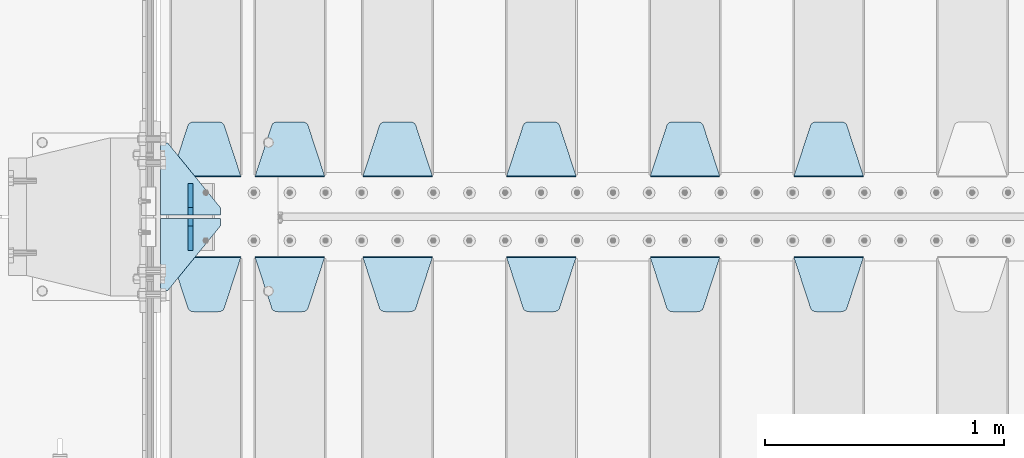
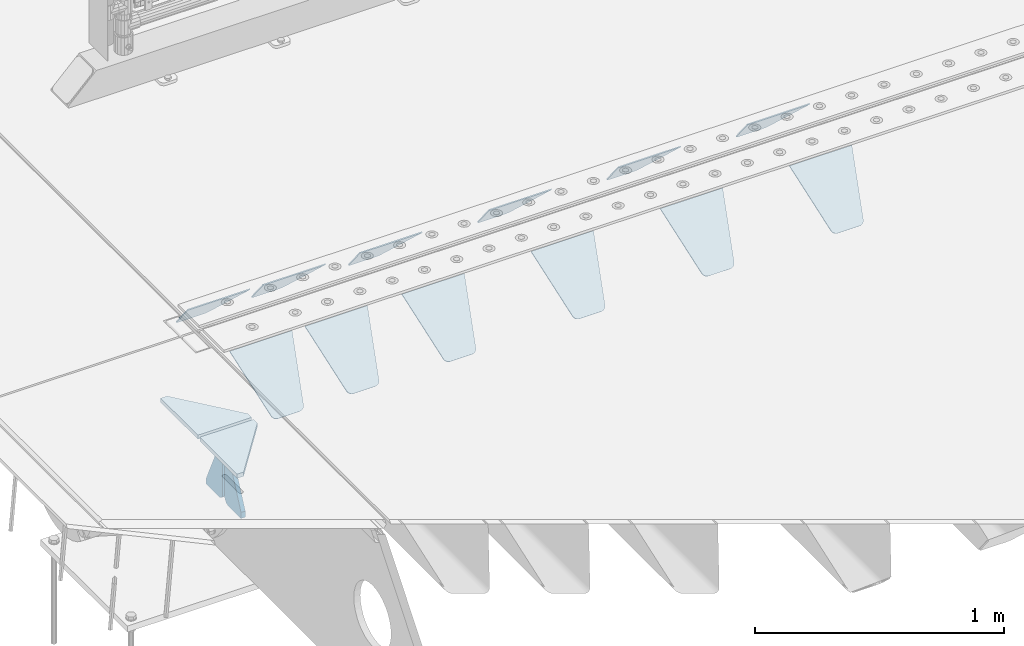
# One storey, part 218 of 270: 16 plates.
"""IFC2X3 building model written with IfcOpenShell, lengths in millimetres."""

from ifc_helpers import new_model, si_unit, frame, origin_with_axes, place, context, subcontext, project, spatial, faceted_brep, material, type_object, element, save


model = new_model("IFC2X3")

# Units and contexts
model_context = context("Model", 3, precision=1e-05, world=origin_with_axes())
body_context = subcontext(model_context, "Body", "Model", "MODEL_VIEW")
ifc_project = project(units=[si_unit("LENGTHUNIT", "METRE", prefix="MILLI"), si_unit("AREAUNIT", "SQUARE_METRE"), si_unit("VOLUMEUNIT", "CUBIC_METRE"), si_unit("MASSUNIT", "GRAM", prefix="KILO"), si_unit("TIMEUNIT", "SECOND"), si_unit("PLANEANGLEUNIT", "RADIAN"), si_unit("SOLIDANGLEUNIT", "STERADIAN"), si_unit("THERMODYNAMICTEMPERATUREUNIT", "DEGREE_CELSIUS"), si_unit("LUMINOUSINTENSITYUNIT", "LUMEN")], contexts=[model_context])

# Site, building, storey
site_placement = place(None, origin_with_axes())
site = spatial("IfcSite", under=ifc_project, at=site_placement, CompositionType="ELEMENT")
building_placement = place(site_placement, origin_with_axes())
building = spatial("IfcBuilding", under=site, at=building_placement, Name="Standard", CompositionType="ELEMENT")
storey_placement = place(building_placement, origin_with_axes())
storey = spatial("IfcBuildingStorey", under=building, at=storey_placement, Name="Undefined", CompositionType="ELEMENT", Elevation=0.0)

# Plates
ifc_material = material(Name="STEEL/S355N")
plate_type_1 = type_object("IfcPlateType", PredefinedType="NOTDEFINED")
plate_1_placement = place(storey_placement, frame((2945.0, -17831.767766953, -1.76776695296758), z_axis=(0.0, 0.707106781186547, -0.707106781186548), x_axis=(-1.0, 0.0, 0.0)))
element("IfcPlate", 1, at=plate_1_placement, inside=storey, type_object=plate_type_1, material=ifc_material, context=body_context, shape_type="Brep", body=[
    faceted_brep([(0.0, -2.5, 0.0), (69.345504679477, -2.5, 300.171731424831), (69.345504679477, 2.5, 300.171731424831), (0.0, 2.5, 0.0), (70.9274061199576, -2.5, 304.8974424154), (70.9274061199576, 2.5, 304.8974424154), (73.3818627772307, -2.49999999999818, 309.234538108527), (73.3818627772307, 2.50000000000182, 309.234538108527), (76.6187032999551, -2.5, 313.023683126103), (76.6187032999551, 2.5, 313.023683126103), (80.5190132704993, -2.5, 316.125672595372), (80.5190132704993, 2.50000000000182, 316.125672595372), (84.9395038596849, -2.49999999999818, 318.426546230476), (84.9395038596849, 2.5, 318.426546230476), (89.7177759439219, -2.49999999999818, 319.841774983275), (89.7177759439219, 2.50000000000182, 319.841774983275), (94.678286292652, -2.5, 320.319366455078), (94.678286292652, 2.5, 320.319366455078), (195.321713707348, -2.5, 320.319366455078), (195.321713707348, 2.5, 320.319366455078), (200.282224056078, -2.49999999999818, 319.841774983275), (200.282224056078, 2.50000000000182, 319.841774983275), (205.060496140315, -2.5, 318.426546230476), (205.060496140315, 2.5, 318.426546230476), (209.480986729501, -2.5, 316.12567259537), (209.480986729501, 2.50000000000182, 316.12567259537), (213.381296700045, -2.5, 313.023683126103), (213.381296700045, 2.5, 313.023683126103), (216.618137222769, -2.49999999999818, 309.234538108525), (216.618137222769, 2.50000000000182, 309.234538108527), (219.072593880042, -2.49999999999818, 304.897442415398), (219.072593880042, 2.50000000000182, 304.897442415397), (220.654495320523, -2.5, 300.171731424831), (220.654495320523, 2.5, 300.171731424831), (290.0, -2.49999999999818, 0.0), (290.0, 2.5, 0.0)], [[[0, 1, 2, 3]], [[1, 4, 5, 2]], [[4, 6, 7, 5]], [[6, 8, 9, 7]], [[8, 10, 11, 9]], [[10, 12, 13, 11]], [[12, 14, 15, 13]], [[14, 16, 17, 15]], [[16, 18, 19, 17]], [[18, 20, 21, 19]], [[20, 22, 23, 21]], [[22, 24, 25, 23]], [[24, 26, 27, 25]], [[26, 28, 29, 27]], [[28, 30, 31, 29]], [[30, 32, 33, 31]], [[32, 34, 35, 33]], [[34, 0, 3, 35]], [[5, 7, 9, 11, 13, 15, 17, 19, 21, 23, 25, 27, 29, 31, 33, 35, 3, 2]], [[34, 32, 30, 28, 26, 24, 22, 20, 18, 16, 14, 12, 10, 8, 6, 4, 1, 0]]]),
])
plate_2_placement = place(storey_placement, frame((2345.0, -17831.767766953, -1.76776695296758), z_axis=(0.0, 0.707106781186547, -0.707106781186548), x_axis=(-1.0, 0.0, 0.0)))
element("IfcPlate", 2, at=plate_2_placement, inside=storey, type_object=plate_type_1, material=ifc_material, context=body_context, shape_type="Brep", body=[
    faceted_brep([(0.0, -2.5, 0.0), (69.345504679477, -2.5, 300.171731424831), (69.345504679477, 2.5, 300.171731424831), (0.0, 2.5, 0.0), (70.9274061199576, -2.5, 304.8974424154), (70.9274061199576, 2.5, 304.8974424154), (73.3818627772307, -2.49999999999818, 309.234538108527), (73.3818627772307, 2.50000000000182, 309.234538108527), (76.6187032999551, -2.5, 313.023683126103), (76.6187032999551, 2.5, 313.023683126103), (80.5190132704993, -2.5, 316.125672595372), (80.5190132704993, 2.50000000000182, 316.125672595372), (84.9395038596849, -2.49999999999818, 318.426546230476), (84.9395038596849, 2.5, 318.426546230476), (89.7177759439219, -2.49999999999818, 319.841774983275), (89.7177759439219, 2.50000000000182, 319.841774983275), (94.678286292652, -2.5, 320.319366455078), (94.678286292652, 2.5, 320.319366455078), (195.321713707348, -2.5, 320.319366455078), (195.321713707348, 2.5, 320.319366455078), (200.282224056078, -2.49999999999818, 319.841774983275), (200.282224056078, 2.50000000000182, 319.841774983275), (205.060496140315, -2.5, 318.426546230476), (205.060496140315, 2.5, 318.426546230476), (209.480986729501, -2.5, 316.12567259537), (209.480986729501, 2.50000000000182, 316.12567259537), (213.381296700045, -2.5, 313.023683126103), (213.381296700045, 2.5, 313.023683126103), (216.618137222769, -2.49999999999818, 309.234538108525), (216.618137222769, 2.50000000000182, 309.234538108527), (219.072593880042, -2.49999999999818, 304.897442415398), (219.072593880042, 2.50000000000182, 304.897442415397), (220.654495320523, -2.5, 300.171731424831), (220.654495320523, 2.5, 300.171731424831), (290.0, -2.49999999999818, 0.0), (290.0, 2.5, 0.0)], [[[0, 1, 2, 3]], [[1, 4, 5, 2]], [[4, 6, 7, 5]], [[6, 8, 9, 7]], [[8, 10, 11, 9]], [[10, 12, 13, 11]], [[12, 14, 15, 13]], [[14, 16, 17, 15]], [[16, 18, 19, 17]], [[18, 20, 21, 19]], [[20, 22, 23, 21]], [[22, 24, 25, 23]], [[24, 26, 27, 25]], [[26, 28, 29, 27]], [[28, 30, 31, 29]], [[30, 32, 33, 31]], [[32, 34, 35, 33]], [[34, 0, 3, 35]], [[5, 7, 9, 11, 13, 15, 17, 19, 21, 23, 25, 27, 29, 31, 33, 35, 3, 2]], [[34, 32, 30, 28, 26, 24, 22, 20, 18, 16, 14, 12, 10, 8, 6, 4, 1, 0]]]),
])
plate_3_placement = place(storey_placement, frame((1745.0, -17831.767766953, -1.76776695296758), z_axis=(0.0, 0.707106781186547, -0.707106781186548), x_axis=(-1.0, 0.0, 0.0)))
element("IfcPlate", 3, at=plate_3_placement, inside=storey, type_object=plate_type_1, material=ifc_material, context=body_context, shape_type="Brep", body=[
    faceted_brep([(0.0, -2.5, 0.0), (69.345504679477, -2.5, 300.171731424831), (69.345504679477, 2.5, 300.171731424831), (0.0, 2.5, 0.0), (70.9274061199576, -2.5, 304.8974424154), (70.9274061199576, 2.5, 304.8974424154), (73.3818627772307, -2.49999999999818, 309.234538108527), (73.3818627772307, 2.50000000000182, 309.234538108527), (76.6187032999551, -2.5, 313.023683126103), (76.6187032999551, 2.5, 313.023683126103), (80.5190132704993, -2.5, 316.125672595372), (80.5190132704993, 2.50000000000182, 316.125672595372), (84.9395038596849, -2.49999999999818, 318.426546230476), (84.9395038596849, 2.5, 318.426546230476), (89.7177759439219, -2.49999999999818, 319.841774983275), (89.7177759439219, 2.50000000000182, 319.841774983275), (94.678286292652, -2.5, 320.319366455078), (94.678286292652, 2.5, 320.319366455078), (195.321713707348, -2.5, 320.319366455078), (195.321713707348, 2.5, 320.319366455078), (200.282224056078, -2.49999999999818, 319.841774983275), (200.282224056078, 2.50000000000182, 319.841774983275), (205.060496140315, -2.5, 318.426546230476), (205.060496140315, 2.5, 318.426546230476), (209.480986729501, -2.5, 316.12567259537), (209.480986729501, 2.50000000000182, 316.12567259537), (213.381296700045, -2.5, 313.023683126103), (213.381296700045, 2.5, 313.023683126103), (216.618137222769, -2.49999999999818, 309.234538108525), (216.618137222769, 2.50000000000182, 309.234538108527), (219.072593880042, -2.49999999999818, 304.897442415398), (219.072593880042, 2.50000000000182, 304.897442415397), (220.654495320523, -2.5, 300.171731424831), (220.654495320523, 2.5, 300.171731424831), (290.0, -2.49999999999818, 0.0), (290.0, 2.5, 0.0)], [[[0, 1, 2, 3]], [[1, 4, 5, 2]], [[4, 6, 7, 5]], [[6, 8, 9, 7]], [[8, 10, 11, 9]], [[10, 12, 13, 11]], [[12, 14, 15, 13]], [[14, 16, 17, 15]], [[16, 18, 19, 17]], [[18, 20, 21, 19]], [[20, 22, 23, 21]], [[22, 24, 25, 23]], [[24, 26, 27, 25]], [[26, 28, 29, 27]], [[28, 30, 31, 29]], [[30, 32, 33, 31]], [[32, 34, 35, 33]], [[34, 0, 3, 35]], [[5, 7, 9, 11, 13, 15, 17, 19, 21, 23, 25, 27, 29, 31, 33, 35, 3, 2]], [[34, 32, 30, 28, 26, 24, 22, 20, 18, 16, 14, 12, 10, 8, 6, 4, 1, 0]]]),
])
plate_4_placement = place(storey_placement, frame((1145.0, -17831.767766953, -1.76776695296758), z_axis=(0.0, 0.707106781186547, -0.707106781186548), x_axis=(-1.0, 0.0, 0.0)))
element("IfcPlate", 4, at=plate_4_placement, inside=storey, type_object=plate_type_1, material=ifc_material, context=body_context, shape_type="Brep", body=[
    faceted_brep([(0.0, -2.5, 0.0), (69.345504679477, -2.5, 300.171731424831), (69.345504679477, 2.5, 300.171731424831), (0.0, 2.5, 0.0), (70.9274061199576, -2.5, 304.8974424154), (70.9274061199576, 2.5, 304.8974424154), (73.3818627772307, -2.49999999999818, 309.234538108527), (73.3818627772307, 2.50000000000182, 309.234538108527), (76.6187032999551, -2.5, 313.023683126103), (76.6187032999551, 2.5, 313.023683126103), (80.5190132704993, -2.5, 316.125672595372), (80.5190132704993, 2.50000000000182, 316.125672595372), (84.9395038596849, -2.49999999999818, 318.426546230476), (84.9395038596849, 2.5, 318.426546230476), (89.7177759439219, -2.49999999999818, 319.841774983275), (89.7177759439219, 2.50000000000182, 319.841774983275), (94.678286292652, -2.5, 320.319366455078), (94.678286292652, 2.5, 320.319366455078), (195.321713707348, -2.5, 320.319366455078), (195.321713707348, 2.5, 320.319366455078), (200.282224056078, -2.49999999999818, 319.841774983275), (200.282224056078, 2.50000000000182, 319.841774983275), (205.060496140315, -2.5, 318.426546230476), (205.060496140315, 2.5, 318.426546230476), (209.480986729501, -2.5, 316.12567259537), (209.480986729501, 2.50000000000182, 316.12567259537), (213.381296700045, -2.5, 313.023683126103), (213.381296700045, 2.5, 313.023683126103), (216.618137222769, -2.49999999999818, 309.234538108525), (216.618137222769, 2.50000000000182, 309.234538108527), (219.072593880042, -2.49999999999818, 304.897442415398), (219.072593880042, 2.50000000000182, 304.897442415397), (220.654495320523, -2.5, 300.171731424831), (220.654495320523, 2.5, 300.171731424831), (290.0, -2.49999999999818, 0.0), (290.0, 2.5, 0.0)], [[[0, 1, 2, 3]], [[1, 4, 5, 2]], [[4, 6, 7, 5]], [[6, 8, 9, 7]], [[8, 10, 11, 9]], [[10, 12, 13, 11]], [[12, 14, 15, 13]], [[14, 16, 17, 15]], [[16, 18, 19, 17]], [[18, 20, 21, 19]], [[20, 22, 23, 21]], [[22, 24, 25, 23]], [[24, 26, 27, 25]], [[26, 28, 29, 27]], [[28, 30, 31, 29]], [[30, 32, 33, 31]], [[32, 34, 35, 33]], [[34, 0, 3, 35]], [[5, 7, 9, 11, 13, 15, 17, 19, 21, 23, 25, 27, 29, 31, 33, 35, 3, 2]], [[34, 32, 30, 28, 26, 24, 22, 20, 18, 16, 14, 12, 10, 8, 6, 4, 1, 0]]]),
])
plate_5_placement = place(storey_placement, frame((695.0, -17831.767766953, -1.76776695296758), z_axis=(0.0, 0.707106781186547, -0.707106781186548), x_axis=(-1.0, 0.0, 0.0)))
element("IfcPlate", 5, at=plate_5_placement, inside=storey, type_object=plate_type_1, material=ifc_material, context=body_context, shape_type="Brep", body=[
    faceted_brep([(0.0, -2.5, 0.0), (69.345504679477, -2.5, 300.171731424831), (69.345504679477, 2.5, 300.171731424831), (0.0, 2.5, 0.0), (70.9274061199576, -2.5, 304.8974424154), (70.9274061199576, 2.5, 304.8974424154), (73.3818627772307, -2.49999999999818, 309.234538108527), (73.3818627772307, 2.50000000000182, 309.234538108527), (76.6187032999551, -2.5, 313.023683126103), (76.6187032999551, 2.5, 313.023683126103), (80.5190132704993, -2.5, 316.125672595372), (80.5190132704993, 2.50000000000182, 316.125672595372), (84.9395038596849, -2.49999999999818, 318.426546230476), (84.9395038596849, 2.5, 318.426546230476), (89.7177759439219, -2.49999999999818, 319.841774983275), (89.7177759439219, 2.50000000000182, 319.841774983275), (94.678286292652, -2.5, 320.319366455078), (94.678286292652, 2.5, 320.319366455078), (195.321713707348, -2.5, 320.319366455078), (195.321713707348, 2.5, 320.319366455078), (200.282224056078, -2.49999999999818, 319.841774983275), (200.282224056078, 2.50000000000182, 319.841774983275), (205.060496140315, -2.5, 318.426546230476), (205.060496140315, 2.5, 318.426546230476), (209.480986729501, -2.5, 316.12567259537), (209.480986729501, 2.50000000000182, 316.12567259537), (213.381296700045, -2.5, 313.023683126103), (213.381296700045, 2.5, 313.023683126103), (216.618137222769, -2.49999999999818, 309.234538108525), (216.618137222769, 2.50000000000182, 309.234538108527), (219.072593880042, -2.49999999999818, 304.897442415398), (219.072593880042, 2.50000000000182, 304.897442415397), (220.654495320523, -2.5, 300.171731424831), (220.654495320523, 2.5, 300.171731424831), (290.0, -2.49999999999818, 0.0), (290.0, 2.5, 0.0)], [[[0, 1, 2, 3]], [[1, 4, 5, 2]], [[4, 6, 7, 5]], [[6, 8, 9, 7]], [[8, 10, 11, 9]], [[10, 12, 13, 11]], [[12, 14, 15, 13]], [[14, 16, 17, 15]], [[16, 18, 19, 17]], [[18, 20, 21, 19]], [[20, 22, 23, 21]], [[22, 24, 25, 23]], [[24, 26, 27, 25]], [[26, 28, 29, 27]], [[28, 30, 31, 29]], [[30, 32, 33, 31]], [[32, 34, 35, 33]], [[34, 0, 3, 35]], [[5, 7, 9, 11, 13, 15, 17, 19, 21, 23, 25, 27, 29, 31, 33, 35, 3, 2]], [[34, 32, 30, 28, 26, 24, 22, 20, 18, 16, 14, 12, 10, 8, 6, 4, 1, 0]]]),
])
plate_6_placement = place(storey_placement, frame((2655.0, -18168.232233044, -1.76776695296576), z_axis=(0.0, -0.707106781186548, -0.707106781186547), x_axis=(1.0, 0.0, 0.0)))
element("IfcPlate", 6, at=plate_6_placement, inside=storey, type_object=plate_type_1, material=ifc_material, context=body_context, shape_type="Brep", body=[
    faceted_brep([(0.0, -2.5, 0.0), (69.345504679477, -2.5, 300.171731424831), (69.345504679477, 2.5, 300.171731424831), (0.0, 2.5, 0.0), (70.9274061199576, -2.5, 304.8974424154), (70.9274061199576, 2.5, 304.8974424154), (73.3818627772307, -2.49999999999818, 309.234538108527), (73.3818627772307, 2.50000000000182, 309.234538108527), (76.6187032999551, -2.5, 313.023683126103), (76.6187032999551, 2.5, 313.023683126103), (80.5190132704993, -2.5, 316.125672595372), (80.5190132704993, 2.50000000000182, 316.125672595372), (84.9395038596849, -2.49999999999818, 318.426546230476), (84.9395038596849, 2.5, 318.426546230476), (89.7177759439219, -2.49999999999818, 319.841774983275), (89.7177759439219, 2.50000000000182, 319.841774983275), (94.678286292652, -2.5, 320.319366455078), (94.678286292652, 2.5, 320.319366455078), (195.321713707348, -2.5, 320.319366455078), (195.321713707348, 2.5, 320.319366455078), (200.282224056078, -2.49999999999818, 319.841774983275), (200.282224056078, 2.50000000000182, 319.841774983275), (205.060496140315, -2.5, 318.426546230476), (205.060496140315, 2.5, 318.426546230476), (209.480986729501, -2.5, 316.12567259537), (209.480986729501, 2.50000000000182, 316.12567259537), (213.381296700045, -2.5, 313.023683126103), (213.381296700045, 2.5, 313.023683126103), (216.618137222769, -2.49999999999818, 309.234538108525), (216.618137222769, 2.50000000000182, 309.234538108527), (219.072593880042, -2.49999999999818, 304.897442415398), (219.072593880042, 2.50000000000182, 304.897442415397), (220.654495320523, -2.5, 300.171731424831), (220.654495320523, 2.5, 300.171731424831), (290.0, -2.49999999999818, 0.0), (290.0, 2.5, 0.0)], [[[0, 1, 2, 3]], [[1, 4, 5, 2]], [[4, 6, 7, 5]], [[6, 8, 9, 7]], [[8, 10, 11, 9]], [[10, 12, 13, 11]], [[12, 14, 15, 13]], [[14, 16, 17, 15]], [[16, 18, 19, 17]], [[18, 20, 21, 19]], [[20, 22, 23, 21]], [[22, 24, 25, 23]], [[24, 26, 27, 25]], [[26, 28, 29, 27]], [[28, 30, 31, 29]], [[30, 32, 33, 31]], [[32, 34, 35, 33]], [[34, 0, 3, 35]], [[5, 7, 9, 11, 13, 15, 17, 19, 21, 23, 25, 27, 29, 31, 33, 35, 3, 2]], [[34, 32, 30, 28, 26, 24, 22, 20, 18, 16, 14, 12, 10, 8, 6, 4, 1, 0]]]),
])
plate_7_placement = place(storey_placement, frame((2055.0, -18168.232233044, -1.76776695296576), z_axis=(0.0, -0.707106781186548, -0.707106781186547), x_axis=(1.0, 0.0, 0.0)))
element("IfcPlate", 7, at=plate_7_placement, inside=storey, type_object=plate_type_1, material=ifc_material, context=body_context, shape_type="Brep", body=[
    faceted_brep([(0.0, -2.5, 0.0), (69.345504679477, -2.5, 300.171731424831), (69.345504679477, 2.5, 300.171731424831), (0.0, 2.5, 0.0), (70.9274061199576, -2.5, 304.8974424154), (70.9274061199576, 2.5, 304.8974424154), (73.3818627772307, -2.49999999999818, 309.234538108527), (73.3818627772307, 2.50000000000182, 309.234538108527), (76.6187032999551, -2.5, 313.023683126103), (76.6187032999551, 2.5, 313.023683126103), (80.5190132704993, -2.5, 316.125672595372), (80.5190132704993, 2.50000000000182, 316.125672595372), (84.9395038596849, -2.49999999999818, 318.426546230476), (84.9395038596849, 2.5, 318.426546230476), (89.7177759439219, -2.49999999999818, 319.841774983275), (89.7177759439219, 2.50000000000182, 319.841774983275), (94.678286292652, -2.5, 320.319366455078), (94.678286292652, 2.5, 320.319366455078), (195.321713707348, -2.5, 320.319366455078), (195.321713707348, 2.5, 320.319366455078), (200.282224056078, -2.49999999999818, 319.841774983275), (200.282224056078, 2.50000000000182, 319.841774983275), (205.060496140315, -2.5, 318.426546230476), (205.060496140315, 2.5, 318.426546230476), (209.480986729501, -2.5, 316.12567259537), (209.480986729501, 2.50000000000182, 316.12567259537), (213.381296700045, -2.5, 313.023683126103), (213.381296700045, 2.5, 313.023683126103), (216.618137222769, -2.49999999999818, 309.234538108525), (216.618137222769, 2.50000000000182, 309.234538108527), (219.072593880042, -2.49999999999818, 304.897442415398), (219.072593880042, 2.50000000000182, 304.897442415397), (220.654495320523, -2.5, 300.171731424831), (220.654495320523, 2.5, 300.171731424831), (290.0, -2.49999999999818, 0.0), (290.0, 2.5, 0.0)], [[[0, 1, 2, 3]], [[1, 4, 5, 2]], [[4, 6, 7, 5]], [[6, 8, 9, 7]], [[8, 10, 11, 9]], [[10, 12, 13, 11]], [[12, 14, 15, 13]], [[14, 16, 17, 15]], [[16, 18, 19, 17]], [[18, 20, 21, 19]], [[20, 22, 23, 21]], [[22, 24, 25, 23]], [[24, 26, 27, 25]], [[26, 28, 29, 27]], [[28, 30, 31, 29]], [[30, 32, 33, 31]], [[32, 34, 35, 33]], [[34, 0, 3, 35]], [[5, 7, 9, 11, 13, 15, 17, 19, 21, 23, 25, 27, 29, 31, 33, 35, 3, 2]], [[34, 32, 30, 28, 26, 24, 22, 20, 18, 16, 14, 12, 10, 8, 6, 4, 1, 0]]]),
])
plate_8_placement = place(storey_placement, frame((1455.0, -18168.232233044, -1.76776695296576), z_axis=(0.0, -0.707106781186548, -0.707106781186547), x_axis=(1.0, 0.0, 0.0)))
element("IfcPlate", 8, at=plate_8_placement, inside=storey, type_object=plate_type_1, material=ifc_material, context=body_context, shape_type="Brep", body=[
    faceted_brep([(0.0, -2.5, 0.0), (69.345504679477, -2.5, 300.171731424831), (69.345504679477, 2.5, 300.171731424831), (0.0, 2.5, 0.0), (70.9274061199576, -2.5, 304.8974424154), (70.9274061199576, 2.5, 304.8974424154), (73.3818627772307, -2.49999999999818, 309.234538108527), (73.3818627772307, 2.50000000000182, 309.234538108527), (76.6187032999551, -2.5, 313.023683126103), (76.6187032999551, 2.5, 313.023683126103), (80.5190132704993, -2.5, 316.125672595372), (80.5190132704993, 2.50000000000182, 316.125672595372), (84.9395038596849, -2.49999999999818, 318.426546230476), (84.9395038596849, 2.5, 318.426546230476), (89.7177759439219, -2.49999999999818, 319.841774983275), (89.7177759439219, 2.50000000000182, 319.841774983275), (94.678286292652, -2.5, 320.319366455078), (94.678286292652, 2.5, 320.319366455078), (195.321713707348, -2.5, 320.319366455078), (195.321713707348, 2.5, 320.319366455078), (200.282224056078, -2.49999999999818, 319.841774983275), (200.282224056078, 2.50000000000182, 319.841774983275), (205.060496140315, -2.5, 318.426546230476), (205.060496140315, 2.5, 318.426546230476), (209.480986729501, -2.5, 316.12567259537), (209.480986729501, 2.50000000000182, 316.12567259537), (213.381296700045, -2.5, 313.023683126103), (213.381296700045, 2.5, 313.023683126103), (216.618137222769, -2.49999999999818, 309.234538108525), (216.618137222769, 2.50000000000182, 309.234538108527), (219.072593880042, -2.49999999999818, 304.897442415398), (219.072593880042, 2.50000000000182, 304.897442415397), (220.654495320523, -2.5, 300.171731424831), (220.654495320523, 2.5, 300.171731424831), (290.0, -2.49999999999818, 0.0), (290.0, 2.5, 0.0)], [[[0, 1, 2, 3]], [[1, 4, 5, 2]], [[4, 6, 7, 5]], [[6, 8, 9, 7]], [[8, 10, 11, 9]], [[10, 12, 13, 11]], [[12, 14, 15, 13]], [[14, 16, 17, 15]], [[16, 18, 19, 17]], [[18, 20, 21, 19]], [[20, 22, 23, 21]], [[22, 24, 25, 23]], [[24, 26, 27, 25]], [[26, 28, 29, 27]], [[28, 30, 31, 29]], [[30, 32, 33, 31]], [[32, 34, 35, 33]], [[34, 0, 3, 35]], [[5, 7, 9, 11, 13, 15, 17, 19, 21, 23, 25, 27, 29, 31, 33, 35, 3, 2]], [[34, 32, 30, 28, 26, 24, 22, 20, 18, 16, 14, 12, 10, 8, 6, 4, 1, 0]]]),
])
plate_9_placement = place(storey_placement, frame((855.0, -18168.232233044, -1.76776695296576), z_axis=(0.0, -0.707106781186548, -0.707106781186547), x_axis=(1.0, 0.0, 0.0)))
element("IfcPlate", 9, at=plate_9_placement, inside=storey, type_object=plate_type_1, material=ifc_material, context=body_context, shape_type="Brep", body=[
    faceted_brep([(0.0, -2.5, 0.0), (69.345504679477, -2.5, 300.171731424831), (69.345504679477, 2.5, 300.171731424831), (0.0, 2.5, 0.0), (70.9274061199576, -2.5, 304.8974424154), (70.9274061199576, 2.5, 304.8974424154), (73.3818627772307, -2.49999999999818, 309.234538108527), (73.3818627772307, 2.50000000000182, 309.234538108527), (76.6187032999551, -2.5, 313.023683126103), (76.6187032999551, 2.5, 313.023683126103), (80.5190132704993, -2.5, 316.125672595372), (80.5190132704993, 2.50000000000182, 316.125672595372), (84.9395038596849, -2.49999999999818, 318.426546230476), (84.9395038596849, 2.5, 318.426546230476), (89.7177759439219, -2.49999999999818, 319.841774983275), (89.7177759439219, 2.50000000000182, 319.841774983275), (94.678286292652, -2.5, 320.319366455078), (94.678286292652, 2.5, 320.319366455078), (195.321713707348, -2.5, 320.319366455078), (195.321713707348, 2.5, 320.319366455078), (200.282224056078, -2.49999999999818, 319.841774983275), (200.282224056078, 2.50000000000182, 319.841774983275), (205.060496140315, -2.5, 318.426546230476), (205.060496140315, 2.5, 318.426546230476), (209.480986729501, -2.5, 316.12567259537), (209.480986729501, 2.50000000000182, 316.12567259537), (213.381296700045, -2.5, 313.023683126103), (213.381296700045, 2.5, 313.023683126103), (216.618137222769, -2.49999999999818, 309.234538108525), (216.618137222769, 2.50000000000182, 309.234538108527), (219.072593880042, -2.49999999999818, 304.897442415398), (219.072593880042, 2.50000000000182, 304.897442415397), (220.654495320523, -2.5, 300.171731424831), (220.654495320523, 2.5, 300.171731424831), (290.0, -2.49999999999818, 0.0), (290.0, 2.5, 0.0)], [[[0, 1, 2, 3]], [[1, 4, 5, 2]], [[4, 6, 7, 5]], [[6, 8, 9, 7]], [[8, 10, 11, 9]], [[10, 12, 13, 11]], [[12, 14, 15, 13]], [[14, 16, 17, 15]], [[16, 18, 19, 17]], [[18, 20, 21, 19]], [[20, 22, 23, 21]], [[22, 24, 25, 23]], [[24, 26, 27, 25]], [[26, 28, 29, 27]], [[28, 30, 31, 29]], [[30, 32, 33, 31]], [[32, 34, 35, 33]], [[34, 0, 3, 35]], [[5, 7, 9, 11, 13, 15, 17, 19, 21, 23, 25, 27, 29, 31, 33, 35, 3, 2]], [[34, 32, 30, 28, 26, 24, 22, 20, 18, 16, 14, 12, 10, 8, 6, 4, 1, 0]]]),
])
plate_10_placement = place(storey_placement, frame((405.0, -18168.232233044, -1.76776695296576), z_axis=(0.0, -0.707106781186548, -0.707106781186547), x_axis=(1.0, 0.0, 0.0)))
element("IfcPlate", 10, at=plate_10_placement, inside=storey, type_object=plate_type_1, material=ifc_material, context=body_context, shape_type="Brep", body=[
    faceted_brep([(0.0, -2.5, 0.0), (69.345504679477, -2.5, 300.171731424831), (69.345504679477, 2.5, 300.171731424831), (0.0, 2.5, 0.0), (70.9274061199576, -2.5, 304.8974424154), (70.9274061199576, 2.5, 304.8974424154), (73.3818627772307, -2.49999999999818, 309.234538108527), (73.3818627772307, 2.50000000000182, 309.234538108527), (76.6187032999551, -2.5, 313.023683126103), (76.6187032999551, 2.5, 313.023683126103), (80.5190132704993, -2.5, 316.125672595372), (80.5190132704993, 2.50000000000182, 316.125672595372), (84.9395038596849, -2.49999999999818, 318.426546230476), (84.9395038596849, 2.5, 318.426546230476), (89.7177759439219, -2.49999999999818, 319.841774983275), (89.7177759439219, 2.50000000000182, 319.841774983275), (94.678286292652, -2.5, 320.319366455078), (94.678286292652, 2.5, 320.319366455078), (195.321713707348, -2.5, 320.319366455078), (195.321713707348, 2.5, 320.319366455078), (200.282224056078, -2.49999999999818, 319.841774983275), (200.282224056078, 2.50000000000182, 319.841774983275), (205.060496140315, -2.5, 318.426546230476), (205.060496140315, 2.5, 318.426546230476), (209.480986729501, -2.5, 316.12567259537), (209.480986729501, 2.50000000000182, 316.12567259537), (213.381296700045, -2.5, 313.023683126103), (213.381296700045, 2.5, 313.023683126103), (216.618137222769, -2.49999999999818, 309.234538108525), (216.618137222769, 2.50000000000182, 309.234538108527), (219.072593880042, -2.49999999999818, 304.897442415398), (219.072593880042, 2.50000000000182, 304.897442415397), (220.654495320523, -2.5, 300.171731424831), (220.654495320523, 2.5, 300.171731424831), (290.0, -2.49999999999818, 0.0), (290.0, 2.5, 0.0)], [[[0, 1, 2, 3]], [[1, 4, 5, 2]], [[4, 6, 7, 5]], [[6, 8, 9, 7]], [[8, 10, 11, 9]], [[10, 12, 13, 11]], [[12, 14, 15, 13]], [[14, 16, 17, 15]], [[16, 18, 19, 17]], [[18, 20, 21, 19]], [[20, 22, 23, 21]], [[22, 24, 25, 23]], [[24, 26, 27, 25]], [[26, 28, 29, 27]], [[28, 30, 31, 29]], [[30, 32, 33, 31]], [[32, 34, 35, 33]], [[34, 0, 3, 35]], [[5, 7, 9, 11, 13, 15, 17, 19, 21, 23, 25, 27, 29, 31, 33, 35, 3, 2]], [[34, 32, 30, 28, 26, 24, 22, 20, 18, 16, 14, 12, 10, 8, 6, 4, 1, 0]]]),
])
plate_11_placement = place(storey_placement, frame((345.0, -17831.767766953, -1.76776695296758), z_axis=(0.0, 0.707106781186547, -0.707106781186548), x_axis=(-1.0, 0.0, 0.0)))
element("IfcPlate", 11, at=plate_11_placement, inside=storey, type_object=plate_type_1, material=ifc_material, context=body_context, shape_type="Brep", body=[
    faceted_brep([(0.0, -2.5, 0.0), (69.345504679477, -2.5, 300.171731424831), (69.345504679477, 2.5, 300.171731424831), (0.0, 2.5, 0.0), (70.9274061199576, -2.5, 304.8974424154), (70.9274061199576, 2.5, 304.8974424154), (73.3818627772307, -2.49999999999818, 309.234538108527), (73.3818627772307, 2.50000000000182, 309.234538108527), (76.6187032999551, -2.5, 313.023683126103), (76.6187032999551, 2.5, 313.023683126103), (80.5190132704993, -2.5, 316.125672595372), (80.5190132704993, 2.50000000000182, 316.125672595372), (84.9395038596849, -2.49999999999818, 318.426546230476), (84.9395038596849, 2.5, 318.426546230476), (89.7177759439219, -2.49999999999818, 319.841774983275), (89.7177759439219, 2.50000000000182, 319.841774983275), (94.678286292652, -2.5, 320.319366455078), (94.678286292652, 2.5, 320.319366455078), (195.321713707348, -2.5, 320.319366455078), (195.321713707348, 2.5, 320.319366455078), (200.282224056078, -2.49999999999818, 319.841774983275), (200.282224056078, 2.50000000000182, 319.841774983275), (205.060496140315, -2.5, 318.426546230476), (205.060496140315, 2.5, 318.426546230476), (209.480986729501, -2.5, 316.12567259537), (209.480986729501, 2.50000000000182, 316.12567259537), (213.381296700045, -2.5, 313.023683126103), (213.381296700045, 2.5, 313.023683126103), (216.618137222769, -2.49999999999818, 309.234538108525), (216.618137222769, 2.50000000000182, 309.234538108527), (219.072593880042, -2.49999999999818, 304.897442415398), (219.072593880042, 2.50000000000182, 304.897442415397), (220.654495320523, -2.5, 300.171731424831), (220.654495320523, 2.5, 300.171731424831), (290.0, -2.49999999999818, 0.0), (290.0, 2.5, 0.0)], [[[0, 1, 2, 3]], [[1, 4, 5, 2]], [[4, 6, 7, 5]], [[6, 8, 9, 7]], [[8, 10, 11, 9]], [[10, 12, 13, 11]], [[12, 14, 15, 13]], [[14, 16, 17, 15]], [[16, 18, 19, 17]], [[18, 20, 21, 19]], [[20, 22, 23, 21]], [[22, 24, 25, 23]], [[24, 26, 27, 25]], [[26, 28, 29, 27]], [[28, 30, 31, 29]], [[30, 32, 33, 31]], [[32, 34, 35, 33]], [[34, 0, 3, 35]], [[5, 7, 9, 11, 13, 15, 17, 19, 21, 23, 25, 27, 29, 31, 33, 35, 3, 2]], [[34, 32, 30, 28, 26, 24, 22, 20, 18, 16, 14, 12, 10, 8, 6, 4, 1, 0]]]),
])
plate_12_placement = place(storey_placement, frame((55.0, -18168.232233044, -1.76776695296576), z_axis=(0.0, -0.707106781186548, -0.707106781186547), x_axis=(1.0, 0.0, 0.0)))
element("IfcPlate", 12, at=plate_12_placement, inside=storey, type_object=plate_type_1, material=ifc_material, context=body_context, shape_type="Brep", body=[
    faceted_brep([(0.0, -2.5, 0.0), (69.345504679477, -2.5, 300.171731424831), (69.345504679477, 2.5, 300.171731424831), (0.0, 2.5, 0.0), (70.9274061199576, -2.5, 304.8974424154), (70.9274061199576, 2.5, 304.8974424154), (73.3818627772307, -2.49999999999818, 309.234538108527), (73.3818627772307, 2.50000000000182, 309.234538108527), (76.6187032999551, -2.5, 313.023683126103), (76.6187032999551, 2.5, 313.023683126103), (80.5190132704993, -2.5, 316.125672595372), (80.5190132704993, 2.50000000000182, 316.125672595372), (84.9395038596849, -2.49999999999818, 318.426546230476), (84.9395038596849, 2.5, 318.426546230476), (89.7177759439219, -2.49999999999818, 319.841774983275), (89.7177759439219, 2.50000000000182, 319.841774983275), (94.678286292652, -2.5, 320.319366455078), (94.678286292652, 2.5, 320.319366455078), (195.321713707348, -2.5, 320.319366455078), (195.321713707348, 2.5, 320.319366455078), (200.282224056078, -2.49999999999818, 319.841774983275), (200.282224056078, 2.50000000000182, 319.841774983275), (205.060496140315, -2.5, 318.426546230476), (205.060496140315, 2.5, 318.426546230476), (209.480986729501, -2.5, 316.12567259537), (209.480986729501, 2.50000000000182, 316.12567259537), (213.381296700045, -2.5, 313.023683126103), (213.381296700045, 2.5, 313.023683126103), (216.618137222769, -2.49999999999818, 309.234538108525), (216.618137222769, 2.50000000000182, 309.234538108527), (219.072593880042, -2.49999999999818, 304.897442415398), (219.072593880042, 2.50000000000182, 304.897442415397), (220.654495320523, -2.5, 300.171731424831), (220.654495320523, 2.5, 300.171731424831), (290.0, -2.49999999999818, 0.0), (290.0, 2.5, 0.0)], [[[0, 1, 2, 3]], [[1, 4, 5, 2]], [[4, 6, 7, 5]], [[6, 8, 9, 7]], [[8, 10, 11, 9]], [[10, 12, 13, 11]], [[12, 14, 15, 13]], [[14, 16, 17, 15]], [[16, 18, 19, 17]], [[18, 20, 21, 19]], [[20, 22, 23, 21]], [[22, 24, 25, 23]], [[24, 26, 27, 25]], [[26, 28, 29, 27]], [[28, 30, 31, 29]], [[30, 32, 33, 31]], [[32, 34, 35, 33]], [[34, 0, 3, 35]], [[5, 7, 9, 11, 13, 15, 17, 19, 21, 23, 25, 27, 29, 31, 33, 35, 3, 2]], [[34, 32, 30, 28, 26, 24, 22, 20, 18, 16, 14, 12, 10, 8, 6, 4, 1, 0]]]),
])
plate_type_2 = type_object("IfcPlateType", PredefinedType="NOTDEFINED")
for number, where, z_axis, x_axis in (
    (13, (259.999999999999, -18008.0, -515.0), (0.0, -1.0, 0.0), (-1.0, 0.0, 0.0)),
    (14, (260.0, -17992.0, -515.0), (0.0, 1.0, 0.0), (-1.0, 0.0, 0.0)),
):
    element("IfcPlate", number, at=place(storey_placement, frame(where, z_axis=z_axis, x_axis=x_axis)), inside=storey, type_object=plate_type_2, material=ifc_material, context=body_context, shape_type="Brep", body=[
        faceted_brep([(0.0, -10.0, 0.0), (0.0, -10.0, 30.0), (0.0, 10.0, 30.0), (0.0, 10.0, 0.0), (220.0, -10.0, 300.0), (220.0, 10.0, 300.0), (250.0, -10.0, 300.0), (250.0, 10.0, 300.0), (250.0, -10.0, 0.0), (250.0, 10.0, 0.0)], [[[0, 1, 2, 3]], [[1, 4, 5, 2]], [[4, 6, 7, 5]], [[6, 8, 9, 7]], [[8, 0, 3, 9]], [[5, 7, 9, 3, 2]], [[8, 6, 4, 1, 0]]]),
    ])
plate_type_3 = type_object("IfcPlateType", PredefinedType="NOTDEFINED")
for number, where, z_axis, x_axis in (
    (15, (135.000000000004, -18140.0, -865.0), (0.0, 0.0, 1.0), (0.0, 1.0, 0.0)),
    (16, (135.000000000004, -17860.0, -865.0), (0.0, 0.0, 1.0), (0.0, -1.0, 0.0)),
):
    element("IfcPlate", number, at=place(storey_placement, frame(where, z_axis=z_axis, x_axis=x_axis)), inside=storey, type_object=plate_type_3, material=ifc_material, context=body_context, shape_type="Brep", body=[
        faceted_brep([(0.0, -10.0, 0.0), (0.0, -10.0, 30.0), (0.0, 10.0, 30.0), (0.0, 10.0, 0.0), (102.0, -10.0, 250.0), (102.0, 10.0, 250.0), (132.0, -10.0, 250.0), (132.0, 10.0, 250.0), (132.0, -10.0, 30.0), (132.0, 10.0, 30.0), (131.544232590368, -10.0, 24.790554669992), (131.544232590368, 10.0, 24.790554669992), (130.190778623579, -10.0, 19.7393957002299), (130.190778623579, 10.0, 19.7393957002299), (127.980762113533, -10.0, 15.0), (127.980762113533, 10.0, 15.0), (124.98133329357, -10.0, 10.7163717094038), (124.98133329357, 10.0, 10.7163717094038), (121.283628290596, -10.0, 7.01866670643062), (121.283628290596, 10.0, 7.01866670643062), (117.0, -10.0, 4.01923788646684), (117.0, 10.0, 4.01923788646684), (112.260604299769, -10.0, 1.80922137642278), (112.260604299769, 10.0, 1.80922137642278), (107.209445330009, -10.0, 0.455767409633722), (107.209445330009, 10.0, 0.455767409633722), (102.0, -10.0, 0.0), (102.0, 10.0, 0.0)], [[[0, 1, 2, 3]], [[1, 4, 5, 2]], [[4, 6, 7, 5]], [[6, 8, 9, 7]], [[8, 10, 11, 9]], [[10, 12, 13, 11]], [[12, 14, 15, 13]], [[14, 16, 17, 15]], [[16, 18, 19, 17]], [[18, 20, 21, 19]], [[20, 22, 23, 21]], [[22, 24, 25, 23]], [[24, 26, 27, 25]], [[26, 0, 3, 27]], [[5, 7, 9, 11, 13, 15, 17, 19, 21, 23, 25, 27, 3, 2]], [[26, 24, 22, 20, 18, 16, 14, 12, 10, 8, 6, 4, 1, 0]]]),
    ])

save(model, "model.ifc")
